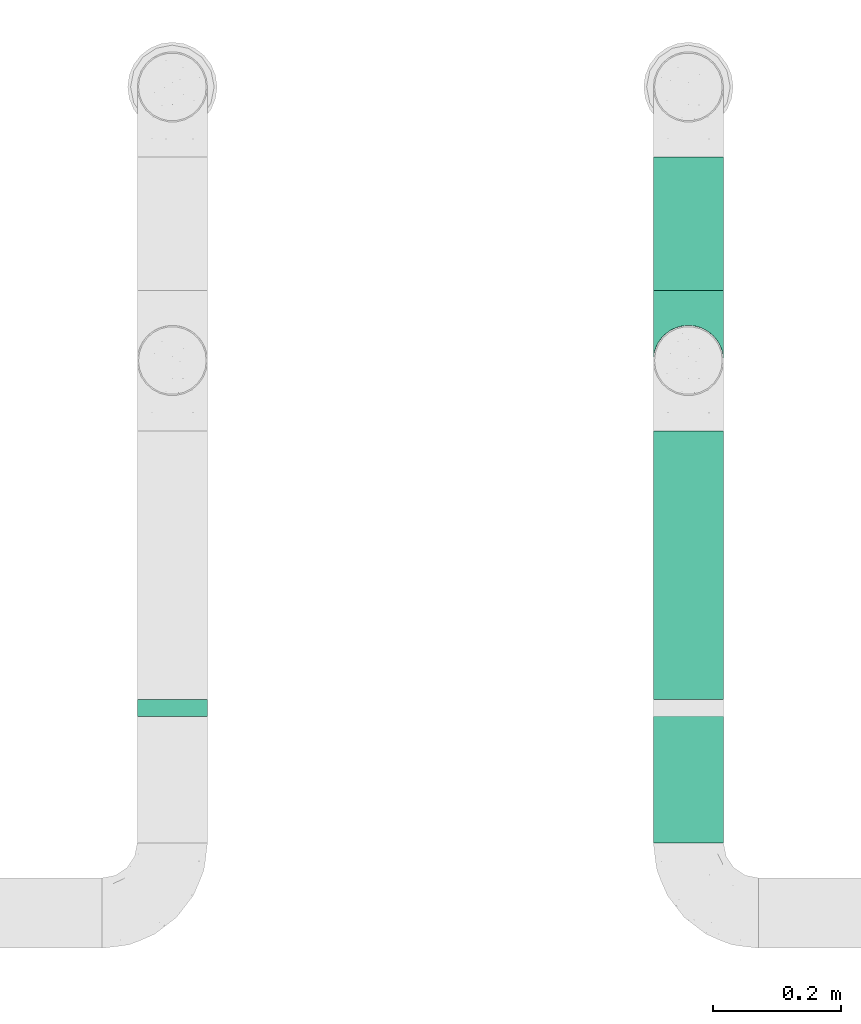
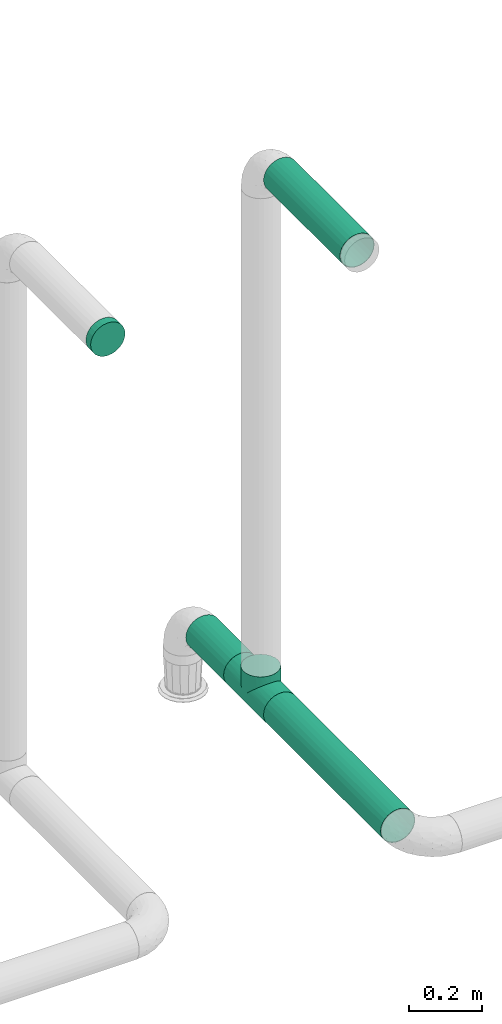
# One storey, part 10 of 103: 3 flow segments, 2 flow fittings.
"""IFC2X3 building model written with IfcOpenShell, lengths in millimetres."""

from ifc_helpers import new_model, entity, si_unit, converted_unit, derived_unit, direction, frame, origin_with_axes, origin_2d_with_axis, place, context, subcontext, project, spatial, hollow_circle, extrude, open_shell, surface_model, source, transform, mapped, material, layer, layer_set, layer_usage, type_object, element, save


model = new_model("IFC2X3")

# Units and contexts
model_context = context("Model", 3, precision=1e-05, world=origin_with_axes(), true_north=direction((0.0, 1.0)))
body_context = subcontext(model_context, "Body", "Model", "MODEL_VIEW")
ifc_project = project(units=[si_unit("AREAUNIT", "SQUARE_METRE"), si_unit("VOLUMEUNIT", "CUBIC_METRE", prefix="DECI"), si_unit("TIMEUNIT", "SECOND"), si_unit("THERMODYNAMICTEMPERATUREUNIT", "DEGREE_CELSIUS"), si_unit("PRESSUREUNIT", "PASCAL"), si_unit("MASSUNIT", "GRAM", prefix="KILO"), si_unit("LENGTHUNIT", "METRE", prefix="MILLI"), si_unit("POWERUNIT", "WATT"), si_unit("ELECTRICCURRENTUNIT", "AMPERE"), si_unit("ELECTRICVOLTAGEUNIT", "VOLT"), derived_unit("VOLUMETRICFLOWRATEUNIT", [(si_unit("VOLUMEUNIT", "CUBIC_METRE", prefix="DECI"), 1), (si_unit("TIMEUNIT", "SECOND"), -1)]), derived_unit("LINEARVELOCITYUNIT", [(si_unit("LENGTHUNIT", "METRE"), 1), (si_unit("TIMEUNIT", "SECOND"), -1)]), derived_unit("MASSDENSITYUNIT", [(si_unit("MASSUNIT", "GRAM", prefix="KILO"), 1), (si_unit("VOLUMEUNIT", "CUBIC_METRE"), -1)]), converted_unit("PLANEANGLEUNIT", "DEGREE", entity("IfcRatioMeasure", 0.01745), si_unit("PLANEANGLEUNIT", "RADIAN"), dimensions=[0, 0, 0, 0, 0, 0, 0])], contexts=[model_context])

# Site, building, storey
site_placement = place(None, origin_with_axes())
site = spatial("IfcSite", under=ifc_project, at=site_placement, CompositionType="ELEMENT")
building_placement = place(site_placement, origin_with_axes())
building = spatial("IfcBuilding", under=site, at=building_placement, Name="mc-building", CompositionType="ELEMENT")
storey_placement = place(building_placement, frame((0.0, 0.0, 5900.0), z_axis=(0.0, 0.0, 1.0), x_axis=(1.0, 0.0, 0.0)))
storey = spatial("IfcBuildingStorey", under=building, at=storey_placement, Name="3. Korrus", CompositionType="ELEMENT", Elevation=5900.0)

# Flow fitting
duct_fitting_type_1 = type_object("IfcDuctFittingType", PredefinedType="JUNCTION")
shared_shape_1 = source(origin_with_axes(), body_context, "Body", "SurfaceModel", [
    surface_model("IfcShellBasedSurfaceModel", [(0.0, -80.0, -55.0), (14.23505, -80.0, -53.12592), (-14.23505, -80.0, -53.12592), (-53.12592, -80.0, 14.23505), (-27.5, -80.0, -47.63139), (-47.63139, -80.0, -27.5), (-38.89087, -80.0, -38.89087), (55.0, -80.0, 0.0), (53.12592, -80.0, 14.23505), (38.89087, -80.0, -38.89087), (27.5, -80.0, -47.63139), (53.12592, -80.0, -14.23505), (47.63139, -80.0, -27.5), (-53.12592, -80.0, -14.23505), (-47.63139, -80.0, 27.5), (-38.89087, -80.0, 38.89087), (14.23505, -80.0, 53.12592), (-27.5, -80.0, 47.63139), (-14.23505, -80.0, 53.12592), (47.63139, -80.0, 27.5), (38.89087, -80.0, 38.89087), (27.5, -80.0, 47.63139), (0.0, -80.0, 55.0), (-55.0, -80.0, 0.0), (0.0, 0.0, 55.0), (-7.4066, -7.4066, 54.49901), (-14.74521, -14.74521, 52.98659), (-21.93978, -21.93978, 50.43457), (-28.89905, -28.89905, 46.79578), (-35.50357, -35.50357, 42.00591), (-41.58668, -41.58668, 35.99373), (-46.92319, -46.92319, 28.69171), (-51.19777, -51.19777, 20.0945), (-50.37866, -80.0, 20.86752), (-54.01174, -54.01174, 10.37938), (-55.0, -55.0, 0.0), (-54.06296, -80.0, 7.11752), (-54.01174, -54.01174, -10.37938), (-51.19777, -51.19777, -20.0945), (-54.06296, -80.0, -7.11752), (-46.92319, -46.92319, -28.69171), (-41.58668, -41.58668, -35.99373), (-50.37866, -80.0, -20.86752), (-35.50357, -35.50357, -42.00591), (-21.93978, -21.93978, -50.43457), (-14.74521, -14.74521, -52.98659), (-7.4066, -7.4066, -54.49901), (0.0, 0.0, -55.0), (-28.89905, -28.89905, -46.79578), (7.4066, -7.4066, -54.49901), (14.74521, -14.74521, -52.98659), (21.93978, -21.93978, -50.43457), (28.89905, -28.89905, -46.79578), (35.50357, -35.50357, -42.00591), (41.58668, -41.58668, -35.99373), (46.92319, -46.92319, -28.69171), (51.19777, -51.19777, -20.0945), (50.37866, -80.0, -20.86752), (54.01174, -54.01174, -10.37938), (55.0, -55.0, 0.0), (54.06296, -80.0, -7.11752), (54.01174, -54.01174, 10.37938), (51.19777, -51.19777, 20.0945), (54.06296, -80.0, 7.11752), (46.92319, -46.92319, 28.69171), (41.58668, -41.58668, 35.99373), (50.37866, -80.0, 20.86752), (35.50357, -35.50357, 42.00591), (21.93978, -21.93978, 50.43457), (14.74521, -14.74521, 52.98659), (7.4066, -7.4066, 54.49901), (28.89905, -28.89905, 46.79578), (-110.0, 0.0, -55.0), (-110.0, -14.23505, -53.12592), (-110.0, 14.23505, -53.12592), (-110.0, 53.12592, 14.23505), (-110.0, 27.5, -47.63139), (-110.0, 47.63139, -27.5), (-110.0, 38.89087, -38.89087), (-110.0, -55.0, 0.0), (-110.0, -53.12592, 14.23505), (-110.0, -38.89087, -38.89087), (-110.0, -27.5, -47.63139), (-110.0, -53.12592, -14.23505), (-110.0, -47.63139, -27.5), (-110.0, 53.12592, -14.23505), (-110.0, 47.63139, 27.5), (-110.0, 38.89087, 38.89087), (-110.0, -14.23505, 53.12592), (-110.0, 27.5, 47.63139), (-110.0, 14.23505, 53.12592), (-110.0, -47.63139, 27.5), (-110.0, -38.89087, 38.89087), (-110.0, -27.5, 47.63139), (-110.0, 0.0, 55.0), (-110.0, 55.0, 0.0), (110.0, 55.0, 0.0), (110.0, 0.0, -55.0), (110.0, 14.23505, -53.12592), (110.0, 27.5, -47.63139), (110.0, 38.89087, -38.89087), (110.0, 47.63139, -27.5), (110.0, -38.89087, -38.89087), (110.0, -53.12592, 14.23505), (110.0, -27.5, -47.63139), (110.0, -14.23505, -53.12592), (110.0, -47.63139, -27.5), (110.0, -53.12592, -14.23505), (110.0, -55.0, 0.0), (110.0, 53.12592, -14.23505), (110.0, 53.12592, 14.23505), (110.0, 47.63139, 27.5), (110.0, 38.89087, 38.89087), (110.0, 0.0, 55.0), (110.0, 27.5, 47.63139), (110.0, 14.23505, 53.12592), (110.0, -47.63139, 27.5), (110.0, -38.89087, 38.89087), (110.0, -27.5, 47.63139), (110.0, -14.23505, 53.12592)], [open_shell([[[0, 1, 2]], [[2, 3, 4]], [[5, 6, 3]], [[6, 4, 3]], [[2, 7, 8]], [[9, 7, 10]], [[1, 10, 7]], [[11, 7, 12]], [[9, 12, 7]], [[7, 2, 1]], [[5, 3, 13]], [[2, 14, 3]], [[2, 15, 14]], [[2, 16, 17]], [[17, 15, 2]], [[16, 18, 17]], [[2, 8, 19]], [[2, 19, 20]], [[2, 20, 21]], [[16, 2, 21]], [[16, 22, 18]], [[23, 13, 3]], [[24, 25, 22]], [[26, 27, 18]], [[25, 26, 18]], [[22, 25, 18]], [[17, 28, 29]], [[17, 18, 27]], [[17, 29, 15]], [[28, 17, 27]], [[30, 31, 14]], [[32, 3, 33]], [[32, 34, 3]], [[35, 36, 34]], [[31, 32, 14]], [[15, 30, 14]], [[34, 36, 3]], [[33, 14, 32]], [[36, 35, 23]], [[30, 15, 29]], [[37, 38, 13]], [[37, 13, 39]], [[40, 41, 5]], [[38, 5, 42]], [[38, 40, 5]], [[37, 39, 35]], [[35, 39, 23]], [[13, 38, 42]], [[41, 6, 5]], [[41, 43, 6]], [[44, 45, 2]], [[46, 47, 0]], [[45, 46, 2]], [[43, 48, 4]], [[44, 4, 48]], [[44, 2, 4]], [[46, 0, 2]], [[43, 4, 6]], [[47, 49, 0]], [[50, 51, 1]], [[49, 50, 1]], [[0, 49, 1]], [[10, 52, 53]], [[10, 1, 51]], [[10, 53, 9]], [[52, 10, 51]], [[54, 55, 12]], [[56, 11, 57]], [[56, 58, 11]], [[59, 60, 58]], [[55, 56, 12]], [[9, 54, 12]], [[58, 60, 11]], [[57, 12, 56]], [[60, 59, 7]], [[54, 9, 53]], [[61, 62, 8]], [[61, 8, 63]], [[64, 65, 19]], [[62, 19, 66]], [[62, 64, 19]], [[61, 63, 59]], [[7, 59, 63]], [[62, 66, 8]], [[65, 20, 19]], [[65, 67, 20]], [[68, 69, 16]], [[70, 24, 22]], [[69, 70, 16]], [[67, 71, 21]], [[68, 21, 71]], [[68, 16, 21]], [[70, 22, 16]], [[67, 21, 20]], [[72, 73, 74]], [[74, 75, 76]], [[77, 78, 75]], [[76, 75, 78]], [[74, 79, 80]], [[81, 79, 82]], [[73, 82, 79]], [[83, 79, 84]], [[81, 84, 79]], [[79, 74, 73]], [[77, 75, 85]], [[74, 86, 75]], [[74, 87, 86]], [[74, 88, 89]], [[89, 87, 74]], [[88, 90, 89]], [[74, 91, 92]], [[91, 74, 80]], [[92, 93, 74]], [[74, 93, 88]], [[88, 94, 90]], [[95, 85, 75]], [[96, 97, 98]], [[99, 96, 98]], [[96, 100, 101]], [[100, 96, 99]], [[102, 97, 103]], [[97, 102, 104]], [[104, 105, 97]], [[102, 103, 106]], [[106, 103, 107]], [[108, 107, 103]], [[109, 96, 101]], [[110, 111, 97]], [[97, 111, 112]], [[113, 97, 114]], [[97, 112, 114]], [[113, 114, 115]], [[116, 103, 97]], [[117, 116, 97]], [[118, 117, 97]], [[119, 118, 97]], [[119, 97, 113]], [[96, 110, 97]], [[24, 113, 115]], [[89, 115, 114]], [[94, 24, 90]], [[90, 24, 115]], [[115, 89, 90]], [[114, 87, 89]], [[86, 112, 111]], [[75, 111, 110]], [[95, 110, 96]], [[87, 112, 86]], [[86, 111, 75]], [[110, 95, 75]], [[112, 87, 114]], [[85, 96, 109]], [[77, 109, 101]], [[95, 96, 85]], [[85, 109, 77]], [[101, 78, 77]], [[101, 100, 78]], [[76, 100, 99]], [[74, 99, 98]], [[47, 98, 97]], [[76, 99, 74]], [[47, 72, 74]], [[98, 47, 74]], [[100, 76, 78]], [[47, 46, 72]], [[45, 44, 73]], [[46, 45, 73]], [[72, 46, 73]], [[82, 48, 43]], [[82, 73, 44]], [[82, 43, 81]], [[48, 82, 44]], [[41, 40, 84]], [[38, 37, 83]], [[40, 38, 84]], [[81, 41, 84]], [[37, 79, 83]], [[83, 84, 38]], [[79, 37, 35]], [[41, 81, 43]], [[49, 97, 105]], [[105, 104, 51]], [[53, 104, 102]], [[53, 52, 104]], [[49, 47, 97]], [[51, 50, 105]], [[52, 51, 104]], [[49, 105, 50]], [[54, 102, 106]], [[56, 106, 107]], [[58, 107, 108]], [[55, 54, 106]], [[58, 56, 107]], [[59, 58, 108]], [[55, 106, 56]], [[102, 54, 53]], [[34, 32, 80]], [[31, 30, 91]], [[32, 31, 91]], [[35, 34, 79]], [[80, 79, 34]], [[32, 91, 80]], [[30, 92, 91]], [[30, 29, 92]], [[27, 26, 88]], [[25, 24, 94]], [[26, 25, 88]], [[29, 28, 93]], [[27, 93, 28]], [[27, 88, 93]], [[25, 94, 88]], [[29, 93, 92]], [[61, 108, 103]], [[62, 103, 116]], [[65, 116, 117]], [[61, 59, 108]], [[64, 62, 116]], [[65, 64, 116]], [[61, 103, 62]], [[117, 67, 65]], [[71, 67, 118]], [[118, 67, 117]], [[68, 118, 119]], [[70, 119, 113]], [[68, 71, 118]], [[70, 69, 119]], [[24, 70, 113]], [[68, 119, 69]]])]),
])
flow_fitting_1_placement = place(storey_placement, frame((9194.13313, 4302.28735, 2345.0), z_axis=(-1.0, 0.0, 0.0), x_axis=(0.0, 1.0, 0.0)))
element("IfcFlowFitting", 1, at=flow_fitting_1_placement, inside=storey, type_object=duct_fitting_type_1, context=body_context, shape_type="MappedRepresentation", body=[
    mapped(shared_shape_1, transform((0.0, 0.0, 0.0), scale=1.0)),
])

# Flow segments
ifc_material = material(Name="FZ1")
ifc_layer = layer(ifc_material, 0.0)
ifc_layer_set = layer_set([ifc_layer], Name="FZ1")
ifc_layer_usage = layer_usage(ifc_layer_set, "AXIS1", "POSITIVE", 0.0)
duct_segment_type = type_object("IfcDuctSegmentType", Name="Safe", PredefinedType="RIGIDSEGMENT")
shared_shape_2 = source(origin_with_axes(), body_context, "Body", "SweptSolid", [
    extrude(hollow_circle(Radius=55.0, WallThickness=2.0, at=origin_2d_with_axis()), frame((0.0, 0.0, 0.0), z_axis=(1.0, 0.0, 0.0), x_axis=(0.0, 1.0, 0.0)), (0.0, 0.0, 1.0), 208.6),
])
flow_segment_1_placement = place(storey_placement, frame((9194.13313, 4412.28735, 2345.0), z_axis=(0.0, 0.0, 1.0), x_axis=(0.0, 1.0, 0.0)))
element("IfcFlowSegment", 2, at=flow_segment_1_placement, inside=storey, type_object=duct_segment_type, material=ifc_layer_usage, Name="Safe", context=body_context, shape_type="MappedRepresentation", body=[
    mapped(shared_shape_2, transform((0.0, 0.0, 0.0), scale=1.0)),
])
shared_shape_3 = source(origin_with_axes(), body_context, "Body", "SweptSolid", [
    extrude(hollow_circle(Radius=55.0, WallThickness=2.0, at=origin_2d_with_axis()), frame((0.0, 0.0, 0.0), z_axis=(1.0, 0.0, 0.0), x_axis=(0.0, 1.0, 0.0)), (0.0, 0.0, 1.0), 645.5),
])
flow_segment_2_placement = place(storey_placement, frame((9194.13313, 3546.80698, 2345.0), z_axis=(0.0, 0.0, 1.0), x_axis=(0.0, 1.0, 0.0)))
element("IfcFlowSegment", 3, at=flow_segment_2_placement, inside=storey, type_object=duct_segment_type, material=ifc_layer_usage, Name="Safe", context=body_context, shape_type="MappedRepresentation", body=[
    mapped(shared_shape_3, transform((0.0, 0.0, 0.0), scale=1.0)),
])
shared_shape_4 = source(origin_with_axes(), body_context, "Body", "SweptSolid", [
    extrude(hollow_circle(Radius=55.0, WallThickness=2.0, at=origin_2d_with_axis()), frame((0.0, 0.0, 0.0), z_axis=(1.0, 0.0, 0.0), x_axis=(0.0, 1.0, 0.0)), (0.0, 0.0, 1.0), 421.1),
])
flow_segment_3_placement = place(storey_placement, frame((9194.13313, 3771.20513, 4144.0), z_axis=(0.0, 0.0, 1.0), x_axis=(0.0, 1.0, 0.0)))
element("IfcFlowSegment", 4, at=flow_segment_3_placement, inside=storey, type_object=duct_segment_type, material=ifc_layer_usage, Name="Safe", context=body_context, shape_type="MappedRepresentation", body=[
    mapped(shared_shape_4, transform((0.0, 0.0, 0.0), scale=1.0)),
])

# Flow fitting
duct_fitting_type_2 = type_object("IfcDuctFittingType", Name="CC", PredefinedType="CONNECTOR")
shared_shape_5 = source(origin_with_axes(), body_context, "Body", "SurfaceModel", [
    surface_model("IfcShellBasedSurfaceModel", [(-6.096, -55.0, 0.0), (-6.096, 0.0, -55.0), (-6.096, -14.23505, -53.12592), (-6.096, -27.5, -47.63139), (-6.096, -38.89087, -38.89087), (-6.096, -47.63139, -27.5), (-6.096, 38.89087, -38.89087), (-6.096, 53.12592, 14.23505), (-6.096, 27.5, -47.63139), (-6.096, 14.23505, -53.12592), (-6.096, 47.63139, -27.5), (-6.096, 53.12592, -14.23505), (-6.096, 55.0, 0.0), (-6.096, -53.12592, -14.23505), (-6.096, -53.12592, 14.23505), (-6.096, -47.63139, 27.5), (-6.096, -38.89087, 38.89087), (-6.096, 0.0, 55.0), (-6.096, -27.5, 47.63139), (-6.096, -14.23505, 53.12592), (-6.096, 38.89087, 38.89087), (-6.096, 47.63139, 27.5), (-6.096, 14.23505, 53.12592), (-6.096, 27.5, 47.63139), (0.0, -14.23505, 53.12592), (0.0, 0.0, 55.0), (0.0, -27.5, 47.63139), (0.0, -38.89087, 38.89087), (0.0, -53.12592, 14.23505), (0.0, -47.63139, 27.5), (0.0, -55.0, 0.0), (0.0, -53.12592, -14.23505), (0.0, -47.63139, -27.5), (0.0, -38.89087, -38.89087), (0.0, -14.23505, -53.12592), (0.0, -27.5, -47.63139), (0.0, 0.0, -55.0), (0.0, 14.23505, -53.12592), (0.0, 27.5, -47.63139), (0.0, 38.89087, -38.89087), (0.0, 53.12592, -14.23505), (0.0, 47.63139, -27.5), (0.0, 55.0, 0.0), (0.0, 53.12592, 14.23505), (0.0, 47.63139, 27.5), (0.0, 38.89087, 38.89087), (0.0, 14.23505, 53.12592), (0.0, 27.5, 47.63139), (20.0, 0.0, -55.0), (20.0, 14.23505, -53.12592), (20.0, -14.23505, -53.12592), (20.0, -53.12592, 14.23505), (20.0, -27.5, -47.63139), (20.0, -47.63139, -27.5), (20.0, -38.89087, -38.89087), (20.0, 55.0, 0.0), (20.0, 53.12592, 14.23505), (20.0, 38.89087, -38.89087), (20.0, 27.5, -47.63139), (20.0, 53.12592, -14.23505), (20.0, 47.63139, -27.5), (20.0, -53.12592, -14.23505), (20.0, -47.63139, 27.5), (20.0, -38.89087, 38.89087), (20.0, 14.23505, 53.12592), (20.0, -27.5, 47.63139), (20.0, -14.23505, 53.12592), (20.0, 47.63139, 27.5), (20.0, 38.89087, 38.89087), (20.0, 27.5, 47.63139), (20.0, 0.0, 55.0), (20.0, -55.0, 0.0)], [open_shell([[[0, 1, 2]], [[3, 0, 2]], [[0, 4, 5]], [[4, 0, 3]], [[6, 1, 7]], [[1, 6, 8]], [[8, 9, 1]], [[6, 7, 10]], [[10, 7, 11]], [[12, 11, 7]], [[13, 0, 5]], [[14, 15, 1]], [[1, 15, 16]], [[17, 16, 18]], [[17, 1, 16]], [[19, 17, 18]], [[20, 21, 1]], [[7, 1, 21]], [[22, 23, 1]], [[23, 20, 1]], [[22, 1, 17]], [[0, 14, 1]], [[24, 25, 17]], [[26, 24, 19]], [[19, 24, 17]], [[16, 27, 18]], [[26, 19, 18]], [[26, 18, 27]], [[28, 29, 15]], [[30, 28, 14]], [[15, 29, 16]], [[28, 15, 14]], [[30, 14, 0]], [[27, 16, 29]], [[31, 30, 0]], [[32, 31, 13]], [[13, 31, 0]], [[4, 33, 5]], [[32, 13, 5]], [[32, 5, 33]], [[34, 35, 3]], [[36, 34, 2]], [[3, 35, 4]], [[34, 3, 2]], [[36, 2, 1]], [[33, 4, 35]], [[37, 36, 1]], [[38, 37, 9]], [[9, 37, 1]], [[6, 39, 8]], [[38, 9, 8]], [[38, 8, 39]], [[40, 41, 10]], [[42, 40, 11]], [[10, 41, 6]], [[40, 10, 11]], [[42, 11, 12]], [[39, 6, 41]], [[43, 42, 12]], [[44, 43, 7]], [[7, 43, 12]], [[20, 45, 21]], [[44, 7, 21]], [[44, 21, 45]], [[46, 47, 23]], [[25, 46, 22]], [[23, 47, 20]], [[46, 23, 22]], [[25, 22, 17]], [[45, 20, 47]], [[48, 49, 50]], [[50, 51, 52]], [[53, 54, 51]], [[52, 51, 54]], [[50, 55, 56]], [[57, 55, 58]], [[49, 58, 55]], [[59, 55, 60]], [[57, 60, 55]], [[55, 50, 49]], [[53, 51, 61]], [[50, 62, 51]], [[63, 62, 50]], [[64, 65, 50]], [[65, 63, 50]], [[64, 66, 65]], [[50, 67, 68]], [[67, 50, 56]], [[68, 69, 50]], [[50, 69, 64]], [[64, 70, 66]], [[71, 61, 51]], [[66, 70, 25]], [[65, 66, 24]], [[24, 66, 25]], [[27, 63, 26]], [[65, 24, 26]], [[65, 26, 63]], [[51, 62, 29]], [[71, 51, 28]], [[29, 62, 27]], [[51, 29, 28]], [[71, 28, 30]], [[63, 27, 62]], [[61, 71, 30]], [[53, 61, 31]], [[31, 61, 30]], [[33, 54, 32]], [[53, 31, 32]], [[53, 32, 54]], [[50, 52, 35]], [[48, 50, 34]], [[35, 52, 33]], [[50, 35, 34]], [[48, 34, 36]], [[54, 33, 52]], [[49, 48, 36]], [[58, 49, 37]], [[37, 49, 36]], [[39, 57, 38]], [[58, 37, 38]], [[58, 38, 57]], [[59, 60, 41]], [[55, 59, 40]], [[41, 60, 39]], [[59, 41, 40]], [[55, 40, 42]], [[57, 39, 60]], [[56, 55, 42]], [[67, 56, 43]], [[43, 56, 42]], [[45, 68, 44]], [[67, 43, 44]], [[67, 44, 68]], [[64, 69, 47]], [[70, 64, 46]], [[47, 69, 45]], [[64, 47, 46]], [[70, 46, 25]], [[68, 45, 69]], [[50, 63, 62]], [[50, 64, 65]], [[50, 56, 67]], [[50, 68, 69]], [[64, 50, 69]]])]),
])
flow_fitting_2_placement = place(storey_placement, frame((8385.80789, 3751.20513, 4144.0), z_axis=(0.0, 0.0, -1.0), x_axis=(0.0, 1.0, 0.0)))
element("IfcFlowFitting", 5, at=flow_fitting_2_placement, inside=storey, type_object=duct_fitting_type_2, Name="CC", context=body_context, shape_type="MappedRepresentation", body=[
    mapped(shared_shape_5, transform((0.0, 0.0, 0.0), scale=1.0)),
])

save(model, "model.ifc")
